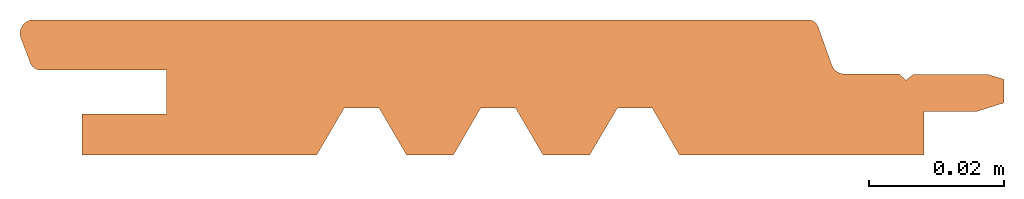
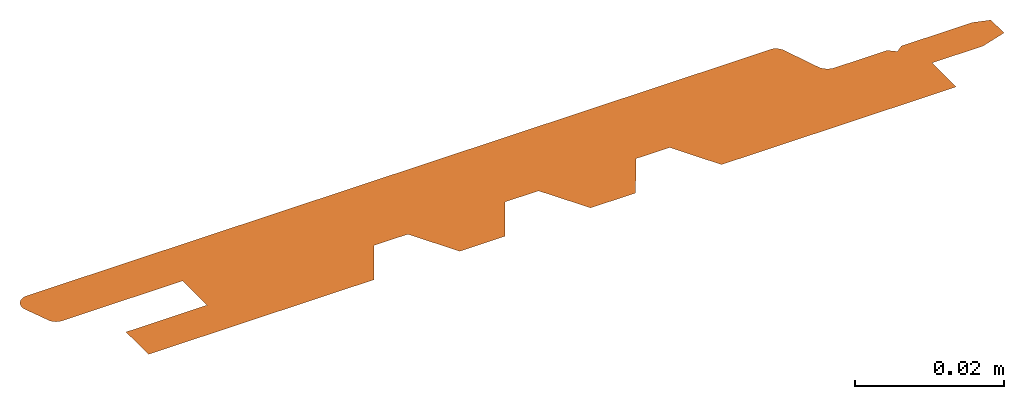
# One storey: 1 proxy.
"""IFC2X3 building model written with IfcOpenShell, lengths in millimetres."""

from ifc_helpers import new_model, entity, si_unit, converted_unit, direction, frame, origin, origin_with_axes, place, context, project, spatial, faceted_brep, element, save


model = new_model("IFC2X3")

# Units and contexts
model_context = context("Model", 3, precision=1e-05, world=origin(), true_north=direction((0.0, 1.0, 0.0)))
ifc_project = project(units=[si_unit("LENGTHUNIT", "METRE", prefix="MILLI"), si_unit("AREAUNIT", "SQUARE_METRE"), si_unit("VOLUMEUNIT", "CUBIC_METRE"), converted_unit("PLANEANGLEUNIT", "DEGREE", entity("IfcPlaneAngleMeasure", 0.01745), si_unit("PLANEANGLEUNIT", "RADIAN"), dimensions=[0, 0, 0, 0, 0, 0, 0]), si_unit("SOLIDANGLEUNIT", "STERADIAN"), si_unit("MASSUNIT", "GRAM"), si_unit("TIMEUNIT", "SECOND"), si_unit("THERMODYNAMICTEMPERATUREUNIT", "DEGREE_CELSIUS"), si_unit("LUMINOUSINTENSITYUNIT", "LUMEN")], contexts=[model_context])

# Site, building, storey
site_placement = place(None, origin_with_axes())
site = spatial("IfcSite", under=ifc_project, at=site_placement, CompositionType="ELEMENT")
building_placement = place(site_placement, origin_with_axes())
building = spatial("IfcBuilding", under=site, at=building_placement, Name="Default Building", CompositionType="ELEMENT")
storey_placement = place(building_placement, origin_with_axes())
storey = spatial("IfcBuildingStorey", under=building, at=storey_placement, Name="Default Building Storey", CompositionType="ELEMENT", Elevation=0.0)

# Proxy
proxy_placement = place(storey_placement, frame((0.5900579947301948, -5.639932965095795e-15, 0.0), z_axis=(0.0, 0.0, 1.0), x_axis=(1.0, 0.0, 0.0)))
element("IfcBuildingElementProxy", 1, at=proxy_placement, inside=storey, context=model_context, shape_type="Brep", body=[
    faceted_brep([(97.833402376441, 5.639932965095795e-15, 2.168825731139172e-19), (134.1535493149559, 5.639932965095795e-15, 2.168825731139172e-19), (134.1535493149559, 6.470159240270041, 2.168825731139172e-19), (142.0463831778959, 6.470159240270041, 1.411898397673865e-18), (145.9974720483883, 7.713836088758282, 1.411898397673865e-18), (145.9974720483883, 11.20888363733329, 1.411898397673865e-18), (143.5564009606546, 11.9530174256902, 1.411898397673865e-18), (132.5584714417996, 11.9530174256902, 2.168825731139172e-19), (131.4643776673999, 11.1073714375759, 2.168825731139172e-19), (130.3921962521895, 12.01970685264783, 2.168825731139172e-19), (122.2664613598776, 12.01970685264783, 2.168825731139172e-19), (122.2004338183463, 12.02182871042408, 2.168825731139172e-19), (122.1345151686834, 12.02617268875093, 2.168825731139172e-19), (122.0687801738769, 12.03273386081629, 2.168825731139172e-19), (122.0033033886188, 12.04150478513243, 2.168825731139172e-19), (121.9381590747477, 12.05247551397565, 2.168825731139172e-19), (121.8734211170228, 12.06563360466894, 2.168825731139172e-19), (121.8091629393261, 12.08096413369397, 2.168825731139172e-19), (121.7454574213873, 12.09844971361682, 2.168825731139172e-19), (121.6823768161258, 12.11807051280864, 2.168825731139172e-19), (121.6199926677033, 12.13980427793767, 2.168825731139172e-19), (121.5583757303808, 12.16362635920865, 2.168825731139172e-19), (121.497595888271, 12.18950973831967, 2.168825731139172e-19), (121.4377220760782, 12.21742505910559, 2.168825731139172e-19), (121.3788222009139, 12.24734066083302, 2.168825731139172e-19), (121.3209630652791, 12.27922261410888, 2.168825731139172e-19), (121.264210291299, 12.3130347593623, 2.168825731139172e-19), (121.2086282462954, 12.34873874785539, 2.168825731139172e-19), (121.1542799697846, 12.38629408517762, 2.168825731139172e-19), (121.1012271019784, 12.4256581771732, 2.168825731139172e-19), (121.0495298138748, 12.46678637825004, 2.168825731139172e-19), (120.9992467390129, 12.50963204201573, 2.168825731139172e-19), (120.9504349069731, 12.55414657418222, 2.168825731139172e-19), (120.9031496786953, 12.60027948768011, 2.168825731139172e-19), (120.8574446836908, 12.64797845991984, 2.168825731139172e-19), (120.8133717592167, 12.69718939213407, 2.168825731139172e-19), (120.770980891484, 12.74785647073492, 2.168825731139172e-19), (120.7303201589643, 12.79992223061653, 2.168825731139172e-19), (120.6914356778611, 12.85332762032976, 2.168825731139172e-19), (120.6543715498059, 12.90801206905703, 2.168825731139172e-19), (120.6191698118396, 12.96391355530942, 2.168825731139172e-19), (120.5858703887348, 13.02096867727039, 2.168825731139172e-19), (120.554511047715, 13.07911272470337, 2.168825731139172e-19), (120.5251273556199, 13.13827975234505, 2.168825731139172e-19), (120.4977526385663, 13.19840265469783, 2.168825731139172e-19), (120.4724179441507, 13.25941324213929, 2.168825731139172e-19), (120.4491520062362, 13.32124231826085, 2.168825731139172e-19), (118.4342986409754, 18.96209117826424, 2.168825731139172e-19), (118.418361935841, 19.00483755266567, 5.945231785364531e-16), (118.4012522774762, 19.04712810345005, 1.118510972596999e-15), (118.3829826845025, 19.08893065202768, 1.571781566040034e-15), (118.3635670581278, 19.13021339112631, 1.953990068383085e-15), (118.3430201715689, 19.17094490899323, 2.264845659800967e-15), (118.3213576588106, 19.21109421329613, 2.504111812408418e-15), (118.2985960027104, 19.25063075470506, 2.671606470232737e-15), (118.2747525224558, 19.28952445013704, 2.767202187738782e-15), (118.2498453603874, 19.32774570564635, 2.790826226801442e-15), (118.2238934681939, 19.36526543894209, 2.742460612051562e-15), (118.1969165924917, 19.40205510151678, 2.622142144553368e-15), (118.1689352598004, 19.4380867003687, 2.429962373802701e-15), (118.1399707609239, 19.47333281930172, 2.166067528067617e-15), (118.1100451347506, 19.50776663978599, 1.830658403124355e-15), (118.0791811514839, 19.54136196136385, 1.423990209473219e-15), (118.0474022953168, 19.57409322158582, 9.463723781506077e-16), (118.0147327465627, 19.60593551546063, 3.981683252851167e-16), (117.9811973632571, 19.63686461440566, -2.20204824423358e-16), (117.9468216622427, 19.66685698468178, -9.082765550908644e-16), (117.9116317997545, 19.69588980530038, -1.665523317661788e-15), (117.8756545515173, 19.72394098538752, -2.491368928273635e-15), (117.8389172923721, 19.75098918099301, -3.385185006671476e-15), (117.8014479754474, 19.77701381133042, -4.346291454338097e-15), (117.763275110889, 19.80199507443728, -5.373956971976314e-15), (117.7244277441675, 19.82591396224193, -6.467399615949588e-15), (117.6849354339774, 19.84875227502688, -7.625787393257599e-15), (117.6448282297466, 19.87049263527682, -8.848238894593953e-15), (117.6041366487713, 19.89111850090077, -1.013382396500448e-14), (117.5628916529962, 19.91061417781939, -1.148156441163581e-14), (117.5211246254552, 19.92896483190572, -1.289043474803555e-14), (117.4788673463929, 19.94615650027323, -1.435936297443785e-14), (117.4361519690828, 19.96217610189945, -1.588723139344078e-14), (117.3930109953622, 19.97701144757948, -1.747287746045446e-14), (117.3494772509017, 19.99065124920069, -1.91150946682734e-14), (117.3055838602289, 20.00308512833164, -2.081263346509943e-14), (117.2613642215231, 20.01430362411903, -2.256420220531712e-14), (1.667608842148085, 20.01430362411903, -2.256506560396185e-14), (1.573588366140066, 19.99518065505232, -2.068361811026987e-14), (1.480576306710779, 19.9716371919378, -1.884051073947251e-14), (1.388780377022108, 19.94372581169077, -1.703985949181791e-14), (1.298405574392905, 19.91150884559467, -1.528568555516497e-14), (1.209653722502003, 19.87505824010395, -1.358190632492586e-14), (1.122723020678533, 19.8344553961742, -1.193232665579628e-14), (1.037807601286105, 19.78979098747878, -1.03406303648099e-14), (0.9550970961892544, 19.74116475791771, -8.810372004692421e-15), (0.8747762132703998, 19.688685298871, -7.344968925886764e-15), (0.7970243239428558, 19.63246980669399, -5.947693644976353e-15), (0.7220150625813012, 19.57264382099639, -4.621666536549259e-15), (0.6499159387639939, 19.5093409442886, -3.369848864823604e-15), (0.5808879631928722, 19.44270254362306, -2.195036170595918e-15), (0.5150852881268215, 19.37287743489527, -1.09985202828055e-15), (0.4526548631311193, 19.30002155050999, -8.674218698194484e-17), (0.3937361069118331, 19.22429759115581, 8.420308913162752e-16), (0.3384605959680035, 19.14587466246397, 1.684393084248108e-15), (0.2869517707569713, 19.06492789736446, 2.438463240964688e-15), (0.2393246600289263, 18.98163806498135, 3.102557383092684e-15), (0.1956856239464415, 18.89619116694234, 3.675192465370014e-15), (0.1561321165624661, 18.80877802200217, 4.155089687560672e-15), (0.1207524681874458, 18.71959383990936, 4.541177350252631e-15), (0.08962568813130084, 18.62883778546648, 4.832593248161148e-15), (0.06282128826103485, 18.53671253375829, 5.028686595592946e-15), (0.04039912776784166, 18.44342381754072, 5.129019479771218e-15), (0.02240927949047874, 18.34917996780153, 5.13336783877602e-15), (0.00889191809327653, 18.25419144851866, 5.041721961916029e-15), (-0.0001227696512743126, 18.15867038665493, 4.854286511414347e-15), (-0.004614652275218956, 18.06283009843962, 4.571480065359788e-15), (-0.004573698572389184, 17.96688461299347, 4.1939341829445e-15), (0.0, 17.87104819436219, 3.722491994075246e-15), (0.009096229525614652, 17.77553486302503, 3.158206316508117e-15), (0.0226946764386011, 17.68055791794753, 2.502337304711417e-15), (0.04076497288749001, 17.58632946024523, 1.756349635707271e-15), (0.06326676455226435, 17.49305991952278, 9.219092381764231e-16), (0.09014980076301808, 17.40095758394544, 8.795721308363328e-19), (1.461071654483065, 13.83542392700667, -6.464301938925171e-19), (1.475816892275595, 13.78133685729446, -6.464340849556768e-19), (1.492357008408629, 13.72777140475344, -6.464379307751393e-19), (1.510673616365955, 13.67478711443499, -6.46441727078e-19), (1.530746354826828, 13.62244288535196, -6.46445469641447e-19), (1.552552910300289, 13.57079690500503, -6.464491543127982e-19), (1.576069041929574, 13.51990658469944, -6.464527769894641e-19), (1.601268608438985, 13.46982849572474, -6.464563336439943e-19), (1.62812359719334, 13.42061830646867, -6.464598203240774e-19), (1.656604155337766, 13.37233072053401, -6.464632331575499e-19), (1.686678622983024, 13.32501941592859, -6.464665683473879e-19), (1.718313568399658, 13.27873698539494, -6.464698221867339e-19), (1.751473825181782, 13.23353487794673, -6.464729910588973e-19), (1.786122531339134, 13.18946334167632, -6.464760714373544e-19), (1.822221170274053, 13.14657136789732, -6.464790599007758e-19), (1.859729613597764, 13.10490663668438, -6.464819531280179e-19), (1.898606165738299, 13.06451546387049, -6.464847479031313e-19), (1.938807610290689, 13.02544274956101, -6.464874411153613e-19), (1.980289258057667, 12.98773192822077, -6.464900297791851e-19), (2.023004996727559, 12.95142492039171, -6.46492511009265e-19), (2.066907342134208, 12.91656208609201, -6.464948820454949e-19), (2.11194749104188, 12.88318217995094, -6.464971402630191e-19), (2.158075375396513, 12.85132230812787, -6.464992831371671e-19), (2.205239717982873, 12.8210178870641, -6.465013082985559e-19), (2.253388089425991, 12.79230260411253, -6.465032134930152e-19), (2.302466966473319, 12.76520838008991, -6.465049965966163e-19), (2.352421791492821, 12.73976533379261, -6.465066556306983e-19), (2.403197033120997, 12.71600174851566, -6.465081887518515e-19), (2.454736247993303, 12.69394404061204, -6.46509594256925e-19), (2.506982143488357, 12.67361673012752, -6.465108705830275e-19), (2.559876641416273, 12.65504241354338, -6.465120163125367e-19), (2.613360942580158, 12.63824173865744, -6.465130301630802e-19), (2.667375592139211, 12.62323338163115, -6.465139110175915e-19), (2.721860545700561, 12.610034026229, -6.465146578942544e-19), (2.776755236066546, 12.59865834527196, -6.465152699615305e-19), (2.8319986405631, 12.58911898432666, -6.465157465381597e-19), (2.887529348874516, 12.58142654764852, -6.465160870981688e-19), (21.70409097784952, 12.58142654764852, -6.465160870981688e-19), (21.70409097784952, 6.037978476488476, -6.465160870981688e-19), (9.163404046879506, 6.037978476488476, -6.465160870981688e-19), (9.163404046879517, 5.639932965095795e-15, 0.0), (44.03812579861847, 5.639932965095795e-15, 2.168825731139172e-19), (48.08998231548834, 6.932165347104807, 2.168825731139172e-19), (53.28934088428835, 6.932165347104807, 2.168825731139172e-19), (57.33720473591467, 5.639932965095795e-15, 2.168825731139172e-19), (64.31890725854159, 5.639932965095795e-15, 2.168825731139172e-19), (68.34873051514568, 6.951531912294728, 2.168825731139172e-19), (73.52527274980068, 6.951531912294728, 2.168825731139172e-19), (77.58868779228926, 0.01113924886181592, 2.168825731139172e-19), (84.53107600895429, 0.01113924886181592, 2.168825731139172e-19), (88.63218694281515, 6.937360453128138, 2.168825731139172e-19), (93.80734636934014, 6.937360453128138, 2.168825731139172e-19)], [[[0, 1, 2, 3, 4, 5, 6, 7, 8, 9, 10, 11, 12, 13, 14, 15, 16, 17, 18, 19, 20, 21, 22, 23, 24, 25, 26, 27, 28, 29, 30, 31, 32, 33, 34, 35, 36, 37, 38, 39, 40, 41, 42, 43, 44, 45, 46, 47, 48, 49, 50, 51, 52, 53, 54, 55, 56, 57, 58, 59, 60, 61, 62, 63, 64, 65, 66, 67, 68, 69, 70, 71, 72, 73, 74, 75, 76, 77, 78, 79, 80, 81, 82, 83, 84, 85, 86, 87, 88, 89, 90, 91, 92, 93, 94, 95, 96, 97, 98, 99, 100, 101, 102, 103, 104, 105, 106, 107, 108, 109, 110, 111, 112, 113, 114, 115, 116, 117, 118, 119, 120, 121, 122, 123, 124, 125, 126, 127, 128, 129, 130, 131, 132, 133, 134, 135, 136, 137, 138, 139, 140, 141, 142, 143, 144, 145, 146, 147, 148, 149, 150, 151, 152, 153, 154, 155, 156, 157, 158, 159, 160, 161, 162, 163, 164, 165, 166, 167, 168, 169, 170, 171, 172]]]),
])

save(model, "model.ifc")
